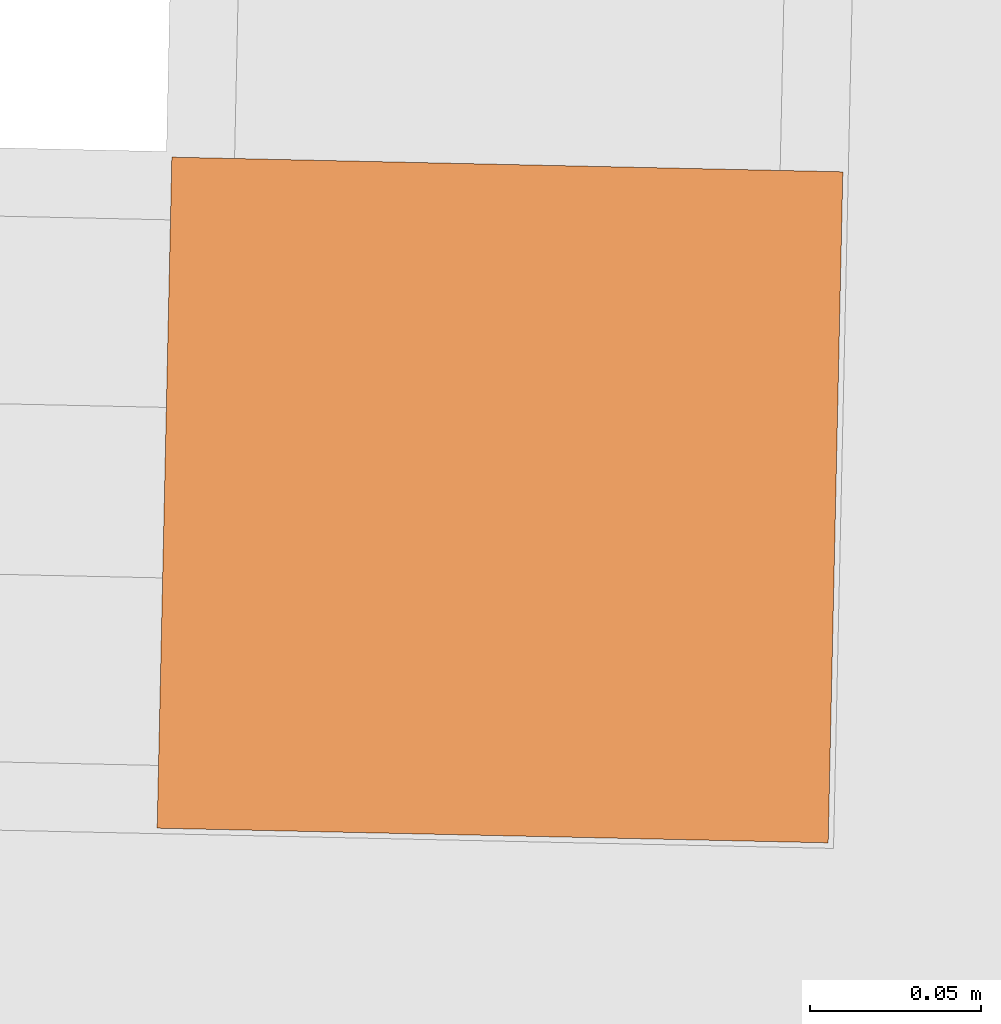
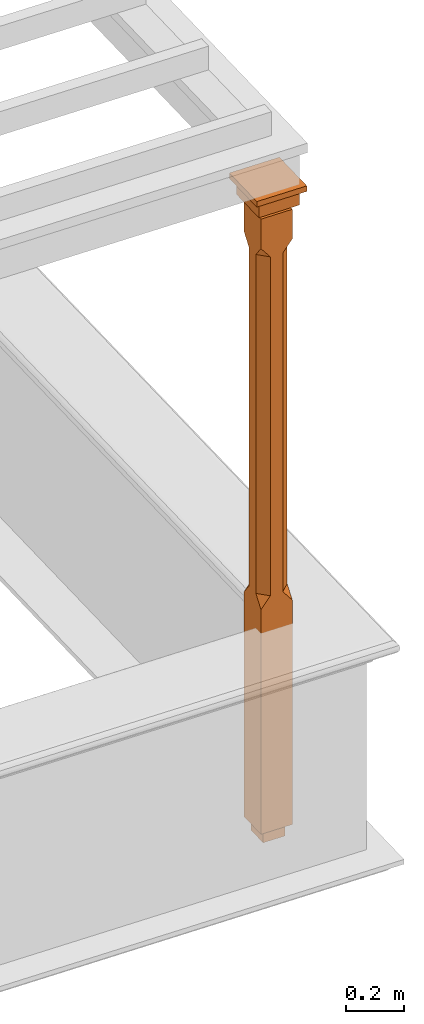
# One storey, part 14 of 14: 1 proxy.
"""IFC2X3 building model written with IfcOpenShell, lengths in metres."""

from ifc_helpers import new_model, si_unit, frame, origin, place, context, subcontext, project, spatial, faceted_brep, element, save


model = new_model("IFC2X3")

# Units and contexts
model_context = context("Model", 3, world=origin())
body_context = subcontext(model_context, "Body", "Model", "MODEL_VIEW")
ifc_project = project(units=[si_unit("PLANEANGLEUNIT", "RADIAN"), si_unit("MASSUNIT", "GRAM", prefix="KILO"), si_unit("FORCEUNIT", "NEWTON", prefix="KILO"), si_unit("LENGTHUNIT", "METRE")], contexts=[model_context])

# Site, building, storey
site_placement = place(None, origin())
site = spatial("IfcSite", under=ifc_project, at=site_placement, CompositionType="ELEMENT")
building_placement = place(None, origin())
building = spatial("IfcBuilding", under=site, at=building_placement, Name="Building plot-17", CompositionType="ELEMENT")
storey_placement = place(None, frame((0.0, 0.0, 6.15)))
storey = spatial("IfcBuildingStorey", under=building, at=storey_placement, Name="Floor 1", CompositionType="ELEMENT", Elevation=6.15)

# Proxy
proxy_placement = place(storey_placement, frame((85.7388039976697, 18.4104869147044, 0.0), z_axis=(0.0, 0.0, 1.0), x_axis=(0.0218670735731853, 0.999760886959149, 0.0)))
element("IfcBuildingElementProxy", 1, at=proxy_placement, inside=storey, Name="pergola post", CompositionType="ELEMENT", context=body_context, shape_type="Brep", held_by="IfcProductRepresentation", body=[
    faceted_brep([(0.0246, -0.0615, 2.47), (0.0615, -0.0246, 2.47), (0.0615, -0.0615, 2.516667), (0.0615, -0.0246, 1.044444), (0.0246, -0.0615, 1.044444), (0.0615, 0.0246, 2.47), (0.0615, 0.0615, 2.516667), (-0.0246, -0.0615, 2.47), (-0.0615, -0.0615, 2.516667), (-0.0246, -0.0615, 1.044444), (0.0615, -0.0615, 0.997778), (0.0615, 0.0246, 1.044444), (0.0246, 0.0615, 2.47), (0.0615, 0.0615, 2.641111), (0.0615, -0.0615, 2.641111), (-0.0615, -0.0615, 2.641111), (-0.0615, -0.0246, 2.47), (-0.0615, -0.0246, 1.044444), (-0.0615, -0.0615, 0.997778), (0.0615, 0.0615, 0.997778), (0.0246, 0.0615, 1.044444), (-0.0246, 0.0615, 2.47), (-0.0615, 0.0615, 2.516667), (0.04305, 0.04305, 2.641111), (0.04305, -0.04305, 2.641111), (-0.0615, 0.0615, 2.641111), (-0.04305, -0.04305, 2.641111), (-0.0615, 0.0246, 2.47), (-0.0615, 0.0246, 1.044444), (0.0615, -0.0615, 0.053333), (-0.0615, -0.0615, 0.053333), (0.0615, 0.0615, 0.053333), (-0.0246, 0.0615, 1.044444), (-0.04305, 0.04305, 2.641111), (0.04305, 0.04305, 2.664444), (0.04305, -0.04305, 2.664444), (-0.04305, -0.04305, 2.664444), (-0.0615, 0.0615, 0.997778), (-0.0615, 0.0615, 0.053333), (-0.04305, -0.04305, 0.053333), (0.04305, -0.04305, 0.053333), (0.04305, 0.04305, 0.053333), (-0.04305, 0.04305, 2.664444), (0.07995, 0.07995, 2.664444), (0.07995, -0.07995, 2.664444), (-0.07995, -0.07995, 2.664444), (-0.04305, 0.04305, 0.053333), (-0.04305, -0.04305, 0.0), (0.04305, -0.04305, 0.0), (0.04305, 0.04305, 0.0), (-0.07995, 0.07995, 2.664444), (0.07995, 0.07995, 2.726667), (0.07995, -0.07995, 2.726667), (-0.07995, -0.07995, 2.726667), (-0.04305, 0.04305, 0.0), (-0.07995, 0.07995, 2.726667), (0.0984, 0.0984, 2.726667), (0.0984, -0.0984, 2.726667), (-0.0984, -0.0984, 2.726667), (-0.0984, 0.0984, 2.726667), (0.0984, 0.0984, 2.75), (0.0984, -0.0984, 2.75), (-0.0984, -0.0984, 2.75), (-0.0984, 0.0984, 2.75)], [[[0, 1, 2]], [[3, 1, 0, 4]], [[1, 5, 6, 2]], [[7, 0, 2, 8]], [[4, 0, 7, 9]], [[3, 4, 10]], [[1, 3, 11, 5]], [[5, 12, 6]], [[13, 14, 2, 6]], [[15, 8, 2, 14]], [[8, 16, 7]], [[9, 7, 16, 17]], [[9, 18, 10, 4]], [[3, 10, 19, 11]], [[20, 12, 5, 11]], [[21, 22, 6, 12]], [[14, 13, 23, 24]], [[13, 6, 22, 25]], [[25, 22, 8, 15]], [[26, 15, 14, 24]], [[16, 8, 22, 27]], [[27, 28, 17, 16]], [[17, 18, 9]], [[29, 10, 18, 30]], [[31, 19, 10, 29]], [[20, 11, 19]], [[12, 20, 32, 21]], [[21, 27, 22]], [[33, 23, 13, 25]], [[23, 34, 35, 24]], [[26, 33, 25, 15]], [[36, 26, 24, 35]], [[28, 27, 21, 32]], [[17, 28, 37, 18]], [[38, 30, 18, 37]], [[29, 30, 39, 40]], [[31, 38, 37, 19]], [[40, 41, 31, 29]], [[32, 20, 19, 37]], [[33, 42, 34, 23]], [[43, 44, 35, 34]], [[42, 33, 26, 36]], [[36, 35, 44, 45]], [[28, 32, 37]], [[46, 39, 30, 38]], [[39, 47, 48, 40]], [[46, 38, 31, 41]], [[49, 41, 40, 48]], [[43, 34, 42, 50]], [[43, 51, 52, 44]], [[45, 50, 42, 36]], [[53, 45, 44, 52]], [[46, 54, 47, 39]], [[54, 46, 41, 49]], [[50, 55, 51, 43]], [[56, 57, 52, 51]], [[55, 50, 45, 53]], [[53, 52, 57, 58]], [[56, 51, 55, 59]], [[56, 60, 61, 57]], [[58, 59, 55, 53]], [[62, 58, 57, 61]], [[59, 63, 60, 56]], [[63, 62, 61, 60]], [[58, 62, 63, 59]], [[47, 54, 49, 48]]]),
])

save(model, "model.ifc")
